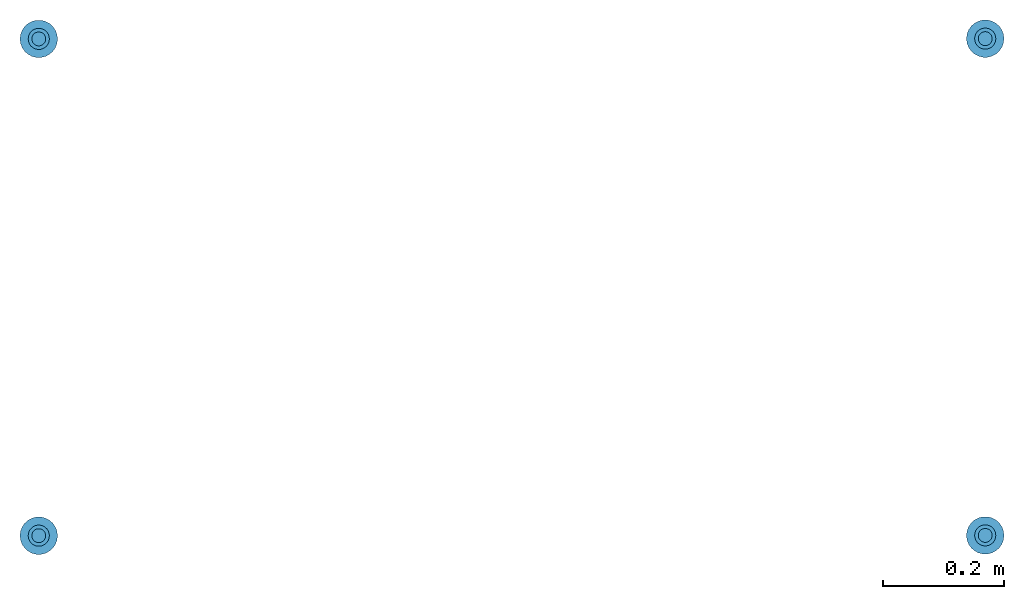
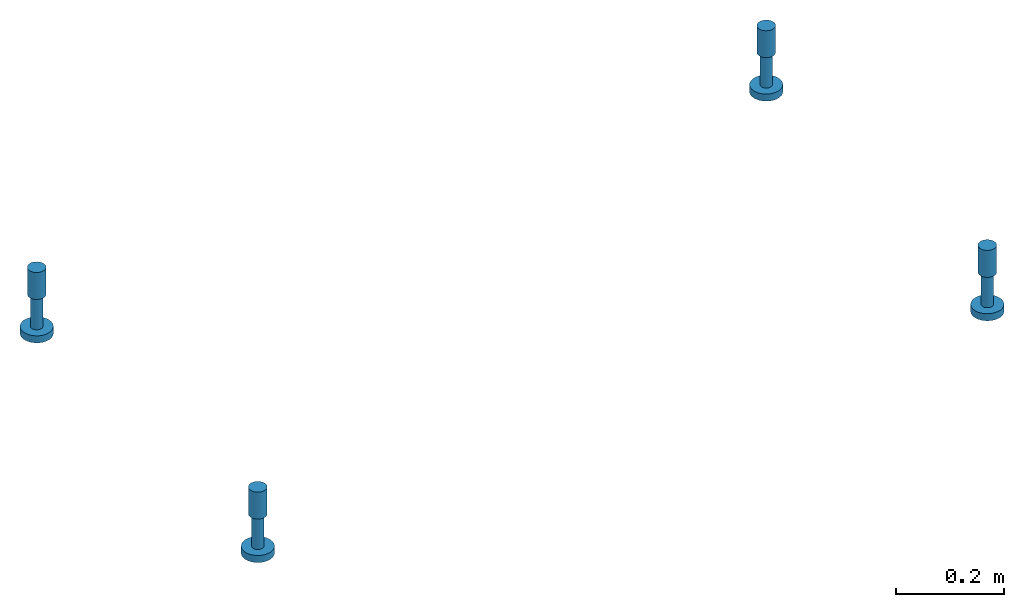
# One storey: 8 reinforcing bars, 4 beams, 4 elements without a shape of their own.
"""IFC2X3 building model written with IfcOpenShell, lengths in millimetres."""

from ifc_helpers import new_model, entity, si_unit, frame, origin_with_axes, origin_2d_with_axis, place, context, subcontext, project, spatial, circle, extrude, source, transform, mapped, material, type_object, element, aggregate, save


model = new_model("IFC2X3")

# Units and contexts
model_context = context("Model", 3, precision=1e-05, world=origin_with_axes())
body_context = subcontext(model_context, "Body", "Model", "MODEL_VIEW")
ifc_project = project(units=[si_unit("LENGTHUNIT", "METRE", prefix="MILLI"), si_unit("AREAUNIT", "SQUARE_METRE"), si_unit("VOLUMEUNIT", "CUBIC_METRE"), si_unit("MASSUNIT", "GRAM", prefix="KILO"), si_unit("TIMEUNIT", "SECOND"), si_unit("PLANEANGLEUNIT", "RADIAN"), si_unit("SOLIDANGLEUNIT", "STERADIAN"), si_unit("THERMODYNAMICTEMPERATUREUNIT", "DEGREE_CELSIUS"), si_unit("LUMINOUSINTENSITYUNIT", "LUMEN")], contexts=[model_context])

# Site, building, storey
site_placement = place(None, origin_with_axes())
site = spatial("IfcSite", under=ifc_project, at=site_placement, CompositionType="ELEMENT")
building_placement = place(site_placement, origin_with_axes())
building = spatial("IfcBuilding", under=site, at=building_placement, Name="Undefined", CompositionType="ELEMENT")
storey_placement = place(building_placement, origin_with_axes())
storey = spatial("IfcBuildingStorey", under=building, at=storey_placement, Name="Undefined", CompositionType="ELEMENT", Elevation=0.0)

# Assembly, beam
assembly_1_placement = place(storey_placement, origin_with_axes())
assembly_1 = element("IfcElementAssembly", 1, at=assembly_1_placement, inside=storey, Name="Steel Assembly", AssemblyPlace="NOTDEFINED", PredefinedType="RIGID_FRAME")
ifc_material_1 = material(Name="STEEL/Steel_Undefined")
beam_type = type_object("IfcBeamType", Name="D35", PredefinedType="NOTDEFINED")
beam_1_placement = place(assembly_1_placement, frame((38363.4326474395, 18319.6156825629, 490.000000000001), z_axis=(5.26700000045822e-06, 0.999999999986129, 0.0), x_axis=(0.0, 0.0, -1.0)))
beam_1 = element("IfcBeam", 2, at=beam_1_placement, type_object=beam_type, material=ifc_material_1, Name="PLA24", ObjectType="D35", context=body_context, shape_type="SweptSolid", body=[
    extrude(circle(Radius=17.5, at=origin_2d_with_axis()), frame((60.9999999999999, 7.27595761418343e-12, -3.63797880709171e-12), z_axis=(-1.0, 0.0, 0.0), x_axis=(0.0, -1.0, 0.0)), (0.0, 0.0, 1.0), 61.0),
])

assembly_2_placement = place(storey_placement, origin_with_axes())
assembly_2 = element("IfcElementAssembly", 3, at=assembly_2_placement, inside=storey, Name="Steel Assembly", AssemblyPlace="NOTDEFINED", PredefinedType="RIGID_FRAME")
beam_2_placement = place(assembly_2_placement, frame((38363.4340151446, 19140.1356825666, 489.999999999994), z_axis=(5.26700000045822e-06, 0.999999999986129, 0.0), x_axis=(0.0, 0.0, -1.0)))
beam_2 = element("IfcBeam", 4, at=beam_2_placement, type_object=beam_type, material=ifc_material_1, Name="PLA24", ObjectType="D35", context=body_context, shape_type="SweptSolid", body=[
    extrude(circle(Radius=17.5, at=origin_2d_with_axis()), frame((60.9999999999999, 7.27595761418343e-12, -3.63797880709171e-12), z_axis=(-1.0, 0.0, 0.0), x_axis=(0.0, -1.0, 0.0)), (0.0, 0.0, 1.0), 61.0),
])

assembly_3_placement = place(storey_placement, origin_with_axes())
assembly_3 = element("IfcElementAssembly", 5, at=assembly_3_placement, inside=storey, Name="Steel Assembly", AssemblyPlace="NOTDEFINED", PredefinedType="RIGID_FRAME")
beam_3_placement = place(assembly_3_placement, frame((36800.1626465109, 18319.1582883518, 490.000000000001), z_axis=(5.26700000045822e-06, 0.999999999986129, 0.0), x_axis=(0.0, 0.0, -1.0)))
beam_3 = element("IfcBeam", 6, at=beam_3_placement, type_object=beam_type, material=ifc_material_1, Name="PLA24", ObjectType="D35", context=body_context, shape_type="SweptSolid", body=[
    extrude(circle(Radius=17.5, at=origin_2d_with_axis()), frame((60.9999999999999, 7.27595761418343e-12, -3.63797880709171e-12), z_axis=(-1.0, 0.0, 0.0), x_axis=(0.0, -1.0, 0.0)), (0.0, 0.0, 1.0), 61.0),
])

assembly_4_placement = place(storey_placement, origin_with_axes())
assembly_4 = element("IfcElementAssembly", 7, at=assembly_4_placement, inside=storey, Name="Steel Assembly", AssemblyPlace="NOTDEFINED", PredefinedType="RIGID_FRAME")
beam_4_placement = place(assembly_4_placement, frame((36800.1740142614, 19139.6782883502, 489.999999999994), z_axis=(5.26700000045822e-06, 0.999999999986129, 0.0), x_axis=(0.0, 0.0, -1.0)))
beam_4 = element("IfcBeam", 8, at=beam_4_placement, type_object=beam_type, material=ifc_material_1, Name="PLA24", ObjectType="D35", context=body_context, shape_type="SweptSolid", body=[
    extrude(circle(Radius=17.5, at=origin_2d_with_axis()), frame((60.9999999999999, 7.27595761418343e-12, -3.63797880709171e-12), z_axis=(-1.0, 0.0, 0.0), x_axis=(0.0, -1.0, 0.0)), (0.0, 0.0, 1.0), 61.0),
])

# Reinforcing bar
ifc_material_2 = material(Name="Undefined")
shared_shape_1 = source(origin_with_axes(), body_context, "Body", "AdvancedSweptSolid", [
    entity("IfcSweptDiskSolid", entity("IfcTrimmedCurve", entity("IfcLine", entity("IfcCartesianPoint", [0.0, 0.0, 0.0]), entity("IfcVector", entity("IfcDirection", [1.0, 0.0, 0.0]), 1.0)), [entity("IfcParameterValue", 0.0)], [entity("IfcParameterValue", 73.0)], True, "PARAMETER"), 11.5, None, 0.0, 73.0),
])
reinforcing_bar_1_placement = place(assembly_1_placement, frame((38363.4326474395, 18319.6156825629, 429.000000000005), z_axis=(-0.999999999986129, 5.2670000004582e-06, 0.0), x_axis=(0.0, 0.0, -1.0)))
reinforcing_bar_1 = element("IfcReinforcingBar", 9, at=reinforcing_bar_1_placement, material=ifc_material_2, Name="REBAR", BarRole="NOTDEFINED", CrossSectionArea=0.0, NominalDiameter=23.0, context=body_context, shape_type="MappedRepresentation", body=[
    mapped(shared_shape_1, transform((0.0, 0.0, 0.0))),
])

shared_shape_2 = source(origin_with_axes(), body_context, "Body", "AdvancedSweptSolid", [
    entity("IfcSweptDiskSolid", entity("IfcTrimmedCurve", entity("IfcLine", entity("IfcCartesianPoint", [0.0, 0.0, 0.0]), entity("IfcVector", entity("IfcDirection", [1.0, 0.0, 0.0]), 1.0)), [entity("IfcParameterValue", 0.0)], [entity("IfcParameterValue", 16.0)], True, "PARAMETER"), 31.0, None, 0.0, 16.0),
])
reinforcing_bar_2_placement = place(assembly_1_placement, frame((38363.4326474395, 18319.6156825629, 353.000000000006), z_axis=(-0.999999999986129, 5.2670000004582e-06, 0.0), x_axis=(0.0, 0.0, -1.0)))
reinforcing_bar_2 = element("IfcReinforcingBar", 10, at=reinforcing_bar_2_placement, material=ifc_material_2, Name="REBAR", BarRole="NOTDEFINED", CrossSectionArea=0.0, NominalDiameter=62.0, context=body_context, shape_type="MappedRepresentation", body=[
    mapped(shared_shape_2, transform((-3.0, 3.63797880709171e-12, 7.27595761418343e-12))),
])

aggregate(assembly_1, [beam_1, reinforcing_bar_1, reinforcing_bar_2])

shared_shape_3 = source(origin_with_axes(), body_context, "Body", "AdvancedSweptSolid", [
    entity("IfcSweptDiskSolid", entity("IfcTrimmedCurve", entity("IfcLine", entity("IfcCartesianPoint", [0.0, 0.0, 0.0]), entity("IfcVector", entity("IfcDirection", [1.0, 0.0, 0.0]), 1.0)), [entity("IfcParameterValue", 0.0)], [entity("IfcParameterValue", 73.0)], True, "PARAMETER"), 11.5, None, 0.0, 73.0),
])
reinforcing_bar_3_placement = place(assembly_2_placement, frame((38363.4340151446, 19140.1356825666, 428.999999999997), z_axis=(-0.999999999986129, 5.2670000004582e-06, 0.0), x_axis=(0.0, 0.0, -1.0)))
reinforcing_bar_3 = element("IfcReinforcingBar", 11, at=reinforcing_bar_3_placement, material=ifc_material_2, Name="REBAR", BarRole="NOTDEFINED", CrossSectionArea=0.0, NominalDiameter=23.0, context=body_context, shape_type="MappedRepresentation", body=[
    mapped(shared_shape_3, transform((0.0, 0.0, 0.0))),
])

shared_shape_4 = source(origin_with_axes(), body_context, "Body", "AdvancedSweptSolid", [
    entity("IfcSweptDiskSolid", entity("IfcTrimmedCurve", entity("IfcLine", entity("IfcCartesianPoint", [0.0, 0.0, 0.0]), entity("IfcVector", entity("IfcDirection", [1.0, 0.0, 0.0]), 1.0)), [entity("IfcParameterValue", 0.0)], [entity("IfcParameterValue", 16.0)], True, "PARAMETER"), 31.0, None, 0.0, 16.0),
])
reinforcing_bar_4_placement = place(assembly_2_placement, frame((38363.4340151446, 19140.1356825666, 352.999999999999), z_axis=(-0.999999999986129, 5.2670000004582e-06, 0.0), x_axis=(0.0, 0.0, -1.0)))
reinforcing_bar_4 = element("IfcReinforcingBar", 12, at=reinforcing_bar_4_placement, material=ifc_material_2, Name="REBAR", BarRole="NOTDEFINED", CrossSectionArea=0.0, NominalDiameter=62.0, context=body_context, shape_type="MappedRepresentation", body=[
    mapped(shared_shape_4, transform((-3.0, 3.63797880709171e-12, 7.27595761418343e-12))),
])

aggregate(assembly_2, [beam_2, reinforcing_bar_3, reinforcing_bar_4])

shared_shape_5 = source(origin_with_axes(), body_context, "Body", "AdvancedSweptSolid", [
    entity("IfcSweptDiskSolid", entity("IfcTrimmedCurve", entity("IfcLine", entity("IfcCartesianPoint", [0.0, 0.0, 0.0]), entity("IfcVector", entity("IfcDirection", [1.0, 0.0, 0.0]), 1.0)), [entity("IfcParameterValue", 0.0)], [entity("IfcParameterValue", 73.0)], True, "PARAMETER"), 11.5, None, 0.0, 73.0),
])
reinforcing_bar_5_placement = place(assembly_3_placement, frame((36800.1626465109, 18319.1582883518, 429.000000000005), z_axis=(-0.999999999986129, 5.2670000004582e-06, 0.0), x_axis=(0.0, 0.0, -1.0)))
reinforcing_bar_5 = element("IfcReinforcingBar", 13, at=reinforcing_bar_5_placement, material=ifc_material_2, Name="REBAR", BarRole="NOTDEFINED", CrossSectionArea=0.0, NominalDiameter=23.0, context=body_context, shape_type="MappedRepresentation", body=[
    mapped(shared_shape_5, transform((0.0, 0.0, 0.0))),
])

shared_shape_6 = source(origin_with_axes(), body_context, "Body", "AdvancedSweptSolid", [
    entity("IfcSweptDiskSolid", entity("IfcTrimmedCurve", entity("IfcLine", entity("IfcCartesianPoint", [0.0, 0.0, 0.0]), entity("IfcVector", entity("IfcDirection", [1.0, 0.0, 0.0]), 1.0)), [entity("IfcParameterValue", 0.0)], [entity("IfcParameterValue", 16.0)], True, "PARAMETER"), 31.0, None, 0.0, 16.0),
])
reinforcing_bar_6_placement = place(assembly_3_placement, frame((36800.1626465109, 18319.1582883518, 353.000000000006), z_axis=(-0.999999999986129, 5.2670000004582e-06, 0.0), x_axis=(0.0, 0.0, -1.0)))
reinforcing_bar_6 = element("IfcReinforcingBar", 14, at=reinforcing_bar_6_placement, material=ifc_material_2, Name="REBAR", BarRole="NOTDEFINED", CrossSectionArea=0.0, NominalDiameter=62.0, context=body_context, shape_type="MappedRepresentation", body=[
    mapped(shared_shape_6, transform((-3.0, 3.63797880709171e-12, 7.27595761418343e-12))),
])

aggregate(assembly_3, [beam_3, reinforcing_bar_5, reinforcing_bar_6])

shared_shape_7 = source(origin_with_axes(), body_context, "Body", "AdvancedSweptSolid", [
    entity("IfcSweptDiskSolid", entity("IfcTrimmedCurve", entity("IfcLine", entity("IfcCartesianPoint", [0.0, 0.0, 0.0]), entity("IfcVector", entity("IfcDirection", [1.0, 0.0, 0.0]), 1.0)), [entity("IfcParameterValue", 0.0)], [entity("IfcParameterValue", 73.0)], True, "PARAMETER"), 11.5, None, 0.0, 73.0),
])
reinforcing_bar_7_placement = place(assembly_4_placement, frame((36800.1740142614, 19139.6782883502, 428.999999999997), z_axis=(-0.999999999986129, 5.2670000004582e-06, 0.0), x_axis=(0.0, 0.0, -1.0)))
reinforcing_bar_7 = element("IfcReinforcingBar", 15, at=reinforcing_bar_7_placement, material=ifc_material_2, Name="REBAR", BarRole="NOTDEFINED", CrossSectionArea=0.0, NominalDiameter=23.0, context=body_context, shape_type="MappedRepresentation", body=[
    mapped(shared_shape_7, transform((0.0, 0.0, 0.0))),
])

shared_shape_8 = source(origin_with_axes(), body_context, "Body", "AdvancedSweptSolid", [
    entity("IfcSweptDiskSolid", entity("IfcTrimmedCurve", entity("IfcLine", entity("IfcCartesianPoint", [0.0, 0.0, 0.0]), entity("IfcVector", entity("IfcDirection", [1.0, 0.0, 0.0]), 1.0)), [entity("IfcParameterValue", 0.0)], [entity("IfcParameterValue", 16.0)], True, "PARAMETER"), 31.0, None, 0.0, 16.0),
])
reinforcing_bar_8_placement = place(assembly_4_placement, frame((36800.1740142614, 19139.6782883502, 352.999999999999), z_axis=(-0.999999999986129, 5.2670000004582e-06, 0.0), x_axis=(0.0, 0.0, -1.0)))
reinforcing_bar_8 = element("IfcReinforcingBar", 16, at=reinforcing_bar_8_placement, material=ifc_material_2, Name="REBAR", BarRole="NOTDEFINED", CrossSectionArea=0.0, NominalDiameter=62.0, context=body_context, shape_type="MappedRepresentation", body=[
    mapped(shared_shape_8, transform((-3.0, 3.63797880709171e-12, 7.27595761418343e-12))),
])

aggregate(assembly_4, [beam_4, reinforcing_bar_7, reinforcing_bar_8])

save(model, "model.ifc")
